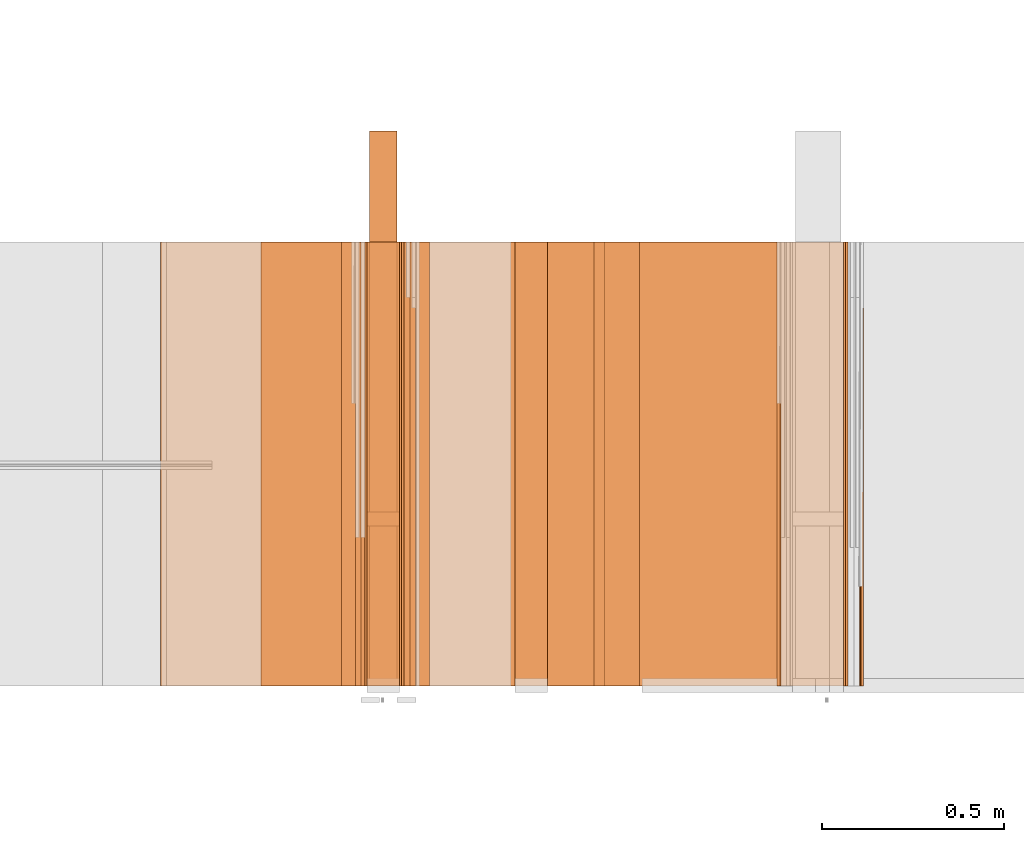
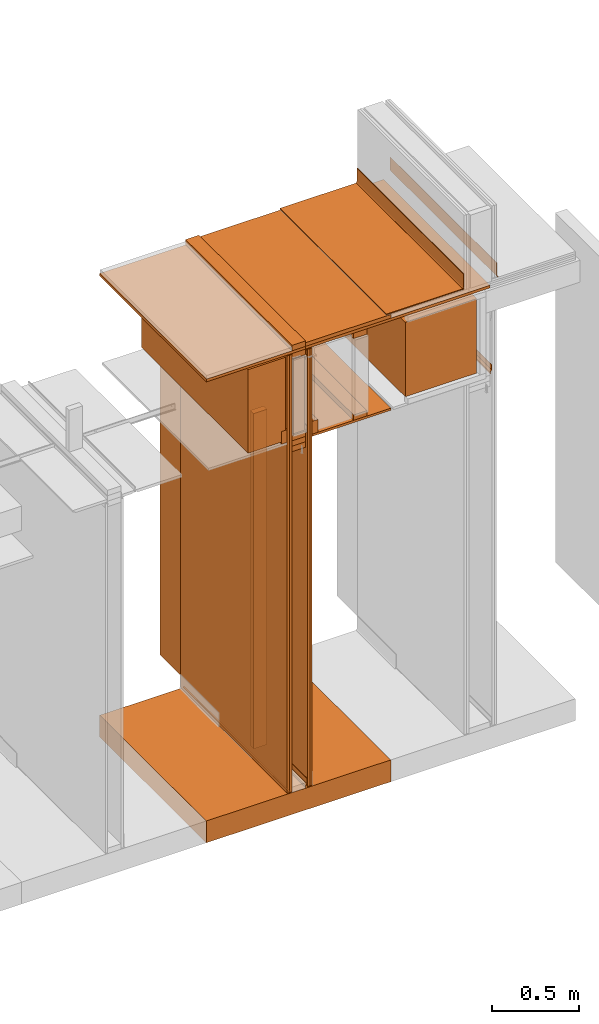
# One storey, part 35 of 64: 31 proxies.
"""IFC4 building model written with IfcOpenShell, lengths in feet."""

from ifc_helpers import new_model, entity, si_unit, converted_unit, frame, origin_with_axes, origin_2d_with_axis, place, context, subcontext, project, spatial, polyline, outline, extrude, material, element, save


model = new_model("IFC4")

# Units and contexts
model_context_1 = context("Model", 3, precision=1e-05, world=origin_with_axes())
plan_context = context("Plan", 2, precision=1e-05, world=origin_2d_with_axis())
model_context_2 = context("Model", 3, precision=1e-05, world=origin_with_axes())
context_of_model_1 = context(None, 3, precision=1e-05, world=origin_with_axes())
context_of_model_2 = context(None, 3, precision=1e-05, world=origin_with_axes())
body_context = subcontext(model_context_2, "Body", "Model", "MODEL_VIEW")
ifc_project = project(units=[converted_unit("PLANEANGLEUNIT", "degree", entity("IfcReal", 0.0174532925199433), si_unit("PLANEANGLEUNIT", "RADIAN"), dimensions=[0, 0, 0, 0, 0, 0, 0]), converted_unit("AREAUNIT", "square foot", entity("IfcReal", 0.09290304), si_unit("AREAUNIT", "SQUARE_METRE"), dimensions=[2, 0, 0, 0, 0, 0, 0]), converted_unit("LENGTHUNIT", "foot", entity("IfcReal", 0.3048), si_unit("LENGTHUNIT", "METRE"), dimensions=[1, 0, 0, 0, 0, 0, 0]), converted_unit("VOLUMEUNIT", "cubic foot", entity("IfcReal", 0.0283168467116885), si_unit("VOLUMEUNIT", "CUBIC_METRE"), dimensions=[3, 0, 0, 0, 0, 0, 0])], contexts=[model_context_1, plan_context, context_of_model_1, context_of_model_2])

# Site, building, storey
site_placement = place(None, origin_with_axes())
site = spatial("IfcSite", under=ifc_project, at=site_placement)
building_placement = place(site_placement, origin_with_axes())
building = spatial("IfcBuilding", under=site, at=building_placement, Name="Building")
storey_placement = place(building_placement, origin_with_axes())
storey = spatial("IfcBuildingStorey", under=building, at=storey_placement, Name="Storey")

# Proxies
proxy_1_placement = place(storey_placement, frame((1385.08854262785, 5.99999987860051, 10.2291668806802), z_axis=(4.37113882867379e-08, -0.999999999999999, -8.51092183247426e-15), x_axis=(1.94707183709394e-07, 0.0, 0.999999999999981)))
element("IfcBuildingElementProxy", 1, at=proxy_1_placement, inside=storey, Name="Generic Models 481:Generic Models 1", PredefinedType="COMPLEX", context=body_context, shape_type="SweptSolid", body=[
    extrude(outline(polyline([(0.841210442265188, 1.5277603110856e-09), (0.840952409690446, 0.0208317411555041), (-0.841210344488539, -1.52776231444079e-09), (-0.840952409690446, -0.0208317411555041), (0.841210442265188, 1.5277603110856e-09)])), frame((0.0104168307749931, -0.841145811900692, -4.91378999315555e-07), z_axis=(0.0, 1.19209303761636e-07, -1.0), x_axis=(0.0123831462115049, -0.999923288822174, -1.19200159076627e-07)), (9.4569436726033e-09, 5.15735579242893e-11, -1.0), 4.00000000752362),
])
ifc_material_1 = material(Name="WALL BASE AS SCHEDULED")
proxy_2_placement = place(storey_placement, frame((1387.47918637093, 5.99999987860051, 10.2500003466769), z_axis=(4.37113882867379e-08, -0.999999999999999, -8.51092183247426e-15), x_axis=(1.94707183709394e-07, 0.0, 0.999999999999981)))
element("IfcBuildingElementProxy", 2, at=proxy_2_placement, inside=storey, material=ifc_material_1, Name="Generic Models 482:Generic Models 1", PredefinedType="COMPLEX", context=body_context, shape_type="SweptSolid", body=[
    extrude(outline(polyline([(0.220647404395689, -6.29889932135151e-10), (0.220442880091705, 0.00356434038693569), (0.218163535311779, 0.00828269806756513), (0.213215401361934, 0.0100073574497083), (-0.0621307594823869, -0.00579188951520919), (-0.0746566692264531, -0.00486853115414599), (-0.0865167811063174, -0.000734690297517212), (-0.0969028489033538, 0.00632791332301642), (-0.105107085793976, 0.0158379745383666), (-0.113815000754955, 0.0101214184931765), (-0.103834498272793, -0.00144763436187376), (-0.0911997814523423, -0.0100393357608477), (-0.0767718836802041, -0.015068177458906), (-0.0615340408201762, -0.0161914508716445), (0.220647404395689, -6.29889932135151e-10)])), frame((0.113048297389755, -0.0126398416918035, -3.92613419174284e-07), z_axis=(2.9828852061986e-13, 1.19209985882662e-07, -1.0), x_axis=(0.998357832431793, 0.0572855435311794, 6.82911327487545e-09)), (1.19549747878978e-09, -3.9874780560778e-11, -1.0), 4.00000000752362),
])
proxy_3_placement = place(storey_placement, frame((1386.73637169865, 5.99999987860051, 10.2500003466769), z_axis=(4.37113882867379e-08, -0.999999999999999, -8.51092183247426e-15), x_axis=(1.94707183709394e-07, 0.0, 0.999999999999981)))
element("IfcBuildingElementProxy", 3, at=proxy_3_placement, inside=storey, material=ifc_material_1, Name="Generic Models 483:Generic Models 1", PredefinedType="COMPLEX", context=body_context, shape_type="SweptSolid", body=[
    extrude(outline(polyline([(0.220471699758777, 4.70219335909461e-14), (0.220618560284454, 0.00356717934719534), (-0.0617877590003132, 0.0151945186382908), (-0.0770054476487198, 0.0138250451530098), (-0.0913501619373563, 0.00856360503083726), (-0.103844324825943, -0.000231237571779394), (-0.113636497261487, -0.0119601335716275), (-0.104837283355201, -0.017535163265631), (-0.0967878757870886, -0.00789370513068918), (-0.0865173433220449, -0.00066411264929456), (-0.0747256200965934, 0.00366092576422873), (-0.0622162712723251, 0.0047866703289759), (0.213349355370041, -0.00655902256294498), (0.218268938538596, -0.00475459118566801), (0.220471699758777, 4.70219335909461e-14)])), frame((0.113048297389755, -0.0218330443105868, -3.93709305460639e-07), z_axis=(2.13063192712774e-14, 1.19209786930696e-07, -1.0), x_axis=(0.9991534948349, -0.0411373302340508, -4.904030070918e-09)), (3.23774618227191e-10, -4.20998902406211e-10, -1.0), 4.00000000752362),
])
proxy_4_placement = place(storey_placement, frame((1385.49674527226, 5.99999987860051, 8.21273314358368), z_axis=(4.37113882867379e-08, -0.999999999999999, -8.51092183247426e-15), x_axis=(1.94707183709394e-07, 0.0, 0.999999999999981)))
element("IfcBuildingElementProxy", 4, at=proxy_4_placement, inside=storey, Name="Generic Models 486:Generic Models 1", PredefinedType="COMPLEX", context=body_context, shape_type="SweptSolid", body=[
    extrude(outline(polyline([(-0.852982848491569, -0.774327352682124), (0.852982946268217, -0.774327352682124), (0.852982946268217, 0.774327352682124), (-0.85298275071492, 0.774327401570448), (-0.852982848491569, -0.774327352682124)])), frame((0.852983044044865, -0.774327206017151, -4.83413600779405e-07), z_axis=(-2.1711843071039e-14, 1.19209289550781e-07, -1.0), x_axis=(-1.0, -1.71943639770689e-07, 0.0)), (8.84101769571544e-09, -3.01153968429446e-09, -1.0), 4.00000000752362),
])
proxy_5_placement = place(storey_placement, frame((1387.33330674059, 5.99999987860051, 8.0949013314535), z_axis=(4.37113882867379e-08, -0.999999999999999, -8.51092183247426e-15), x_axis=(1.94707183709394e-07, 0.0, 0.999999999999981)))
element("IfcBuildingElementProxy", 5, at=proxy_5_placement, inside=storey, Name="Generic Models 487:Generic Models 1", PredefinedType="COMPLEX", context=body_context, shape_type="SweptSolid", body=[
    extrude(outline(polyline([(0.0909011349023327, -1.52771368754651e-09), (0.106510742912142, -0.0224037100793183), (0.110784095768228, -0.0194262812803854), (0.0939412186719145, 0.00474751612851078), (-0.0261054912049157, 0.0262034236847025), (-0.0684096397260043, -0.00327164942784885), (-0.107302623764267, 0.00367967978369181), (-0.1082189865117, -0.00144740758497962), (-0.0672022875623284, -0.00877830727280086), (-0.0248981451522803, 0.0206967635481103), (0.0909011349023327, -1.52771368754651e-09)])), frame((0.106276176732982, -0.0204650267807087, -3.93546216320895e-07), z_axis=(-2.86421862789876e-12, 1.19209985882662e-07, -1.0), x_axis=(0.984400570392609, -0.175941362977028, -2.09736619183332e-08)), (-1.20826360028303e-09, -9.42844552431765e-11, -1.0), 4.00000000752362),
])
ifc_material_2 = material(Name="ACOUSTICAL SEALANT", Category="sealant")
proxy_6_placement = place(storey_placement, frame((1382.98955802217, 5.99999987860051, 0.0), z_axis=(4.37113882867379e-08, -0.999999999999999, -8.51092183247426e-15), x_axis=(1.94707183709394e-07, 0.0, 0.999999999999981)))
element("IfcBuildingElementProxy", 6, at=proxy_6_placement, inside=storey, material=ifc_material_2, Name="Generic Models 246:Generic Models 1", PredefinedType="COMPLEX", context=body_context, shape_type="SweptSolid", body=[
    extrude(outline(polyline([(0.0175297320783725, 1.21719171997307e-09), (-0.00760452534631872, 0.0185696447874344), (-0.0101125697065096, 0.00747135049587707), (-0.0199842895564484, 0.00181347361657025), (0.0051499686321229, -0.0167561721257142), (0.0150216861904215, -0.0110982927637972), (0.0175297320783725, 1.21719171997307e-09)])), frame((0.0104166711240596, -0.0171509025657545, -3.9315117507417e-07), z_axis=(1.14723269946382e-12, 1.19208550586336e-07, -1.0), x_axis=(-0.594228446483612, -0.804296314716339, -9.58762740310704e-08)), (-1.04803887790439e-10, 1.77274347978873e-10, -1.0), 4.00000000752362),
])
proxy_7_placement = place(storey_placement, frame((1383.37503268024, 5.99999987860051, 0.0208333330815585), z_axis=(4.37113882867379e-08, -0.999999999999999, -8.51092183247426e-15), x_axis=(1.94707183709394e-07, 0.0, 0.999999999999981)))
element("IfcBuildingElementProxy", 7, at=proxy_7_placement, inside=storey, Name="Generic Models 25:Generic Models 1", PredefinedType="COMPLEX", context=body_context, shape_type="SweptSolid", body=[
    extrude(outline(polyline([(-5.01041650146324, -0.0260416674977682), (5.01041650146324, -0.0260416674977682), (5.01041650146324, 0.0260416705532884), (-5.01041650146324, 0.0260416674977682), (-5.01041650146324, -0.0260416674977682)])), frame((5.01041650146324, -0.0260406927868059, -3.10445129795532e-09), z_axis=(-3.16621932123194e-14, 1.19209289550781e-07, -1.0), x_axis=(1.0, 1.94707183709397e-07, -8.51092267950722e-15)), (-1.26760935081904e-09, 1.6927841073322e-10, -1.0), 4.00000000752362),
])
ifc_material_3 = material(Name="STRUCTURAL FLOOR", Category="concrete")
proxy_8_placement = place(storey_placement, frame((1381.18233267717, 5.99999987860051, -0.500000006179484), z_axis=(4.37113882867379e-08, -0.999999999999999, -8.51092183247426e-15), x_axis=(1.94707183709394e-07, 0.0, 0.999999999999981)))
element("IfcBuildingElementProxy", 8, at=proxy_8_placement, inside=storey, material=ifc_material_3, Name="Generic Models 28:Generic Models 1", PredefinedType="COMPLEX", context=body_context, shape_type="SweptSolid", body=[
    extrude(outline(polyline([(-0.250000003089742, -2.00000002471794), (0.250000003089742, -2.00000002471794), (0.250000003089742, 2.00000002471794), (-0.250000003089742, 2.00000002471794), (-0.250000003089742, -2.00000002471794)])), frame((0.250000394196335, -2.00000002471794, -2.3841858204817e-07), z_axis=(0.0, 1.19209289550781e-07, -1.0), x_axis=(1.0, 1.94707183709397e-07, -8.51092267950722e-15)), (4.23030166452065e-10, -9.26341314766432e-09, -1.0), 4.00000000752362),
])
proxy_9_placement = place(storey_placement, frame((1383.33338139251, 5.99999987860051, 0.0115680431010901), z_axis=(4.37113882867379e-08, -0.999999999999999, -8.51092183247426e-15), x_axis=(1.94707183709394e-07, 0.0, 0.999999999999981)))
element("IfcBuildingElementProxy", 9, at=proxy_9_placement, inside=storey, Name="Generic Models 29:Generic Models 1", PredefinedType="COMPLEX", context=body_context, shape_type="SweptSolid", body=[
    extrude(outline(polyline([(0.0667668759255741, 0.0152567137531408), (0.106276176732982, 0.0152567137531408), (0.106276176732982, 0.0204650481693505), (0.0646095075143447, 0.0204650481693505), (0.0281511742396774, -0.0159932851053168), (-0.089483129061035, -0.0159932866330769), (-0.108790967681902, 0.00331456230017124), (-0.112473822915022, -0.000368285962543022), (-0.0916404974722643, -0.0212016195215265), (0.0303085395953865, -0.0212016210492867), (0.0667668759255741, 0.0152567137531408)])), frame((0.106276176732982, -0.0204650283084689, -3.93546216320895e-07), z_axis=(-2.48385014813002e-12, 1.19210000093517e-07, -1.0), x_axis=(-1.0, -1.93341818999215e-07, 0.0)), (9.89209492097132e-10, -1.26986490767145e-10, -1.0), 4.00000000752362),
])
proxy_10_placement = place(storey_placement, frame((1383.04162213183, 5.99999987860051, 7.81249968711472), z_axis=(4.37113882867379e-08, -0.999999999999999, -8.51092183247426e-15), x_axis=(1.94707183709394e-07, 0.0, 0.999999999999981)))
element("IfcBuildingElementProxy", 10, at=proxy_10_placement, inside=storey, Name="Generic Models 359:Generic Models 1", PredefinedType="COMPLEX", context=body_context, shape_type="SweptSolid", body=[
    extrude(outline(polyline([(-0.145833333098669, -0.0625000007724355), (0.145833333098669, -0.0625000007724355), (0.145833333098669, 0.0625000007724355), (-0.145833333098669, 0.062500006883476), (-0.145833333098669, -0.0625000007724355)])), frame((0.0625000313276381, -0.145833320876588, -4.08491298529716e-07), z_axis=(-1.6389038902582e-14, 1.19209246918217e-07, -1.0), x_axis=(-1.94707197920252e-07, 1.0, 1.19209254023644e-07)), (5.71730267295845e-11, 5.40085143274638e-10, -1.0), 4.00000000752362),
])
proxy_11_placement = place(storey_placement, frame((1382.08594534967, 5.99999987860051, 8.1138363660477), z_axis=(4.37113882867379e-08, -0.999999999999999, -8.51092183247426e-15), x_axis=(1.94707183709394e-07, 0.0, 0.999999999999981)))
element("IfcBuildingElementProxy", 11, at=proxy_11_placement, inside=storey, Name="Generic Models 35:Generic Models 1", PredefinedType="COMPLEX", context=body_context, shape_type="SweptSolid", body=[
    extrude(outline(polyline([(-0.717593576964431, -0.513735034177935), (1.19485684580064, -0.513735034177935), (1.19485684580064, 0.300924672581392), (-0.477263122171242, 0.300924697025554), (-0.477263073282918, 0.212810239375733), (-0.717593576964431, 0.212810239375733), (-0.717593576964431, -0.513735034177935)])), frame((0.717593674741079, -0.513734887512963, -4.52348569800187e-07), z_axis=(-8.97603016491045e-15, 1.19209332183345e-07, -1.0), x_axis=(1.0, 1.94707197920252e-07, 0.0)), (-5.62830615447041e-10, 1.27540444871954e-09, -1.0), 4.00000000752362),
])
proxy_12_placement = place(storey_placement, frame((1383.06254789898, 6.99999998873613, 0.125000001544871), z_axis=(4.37113882867379e-08, -0.999999999999999, -8.51092183247426e-15), x_axis=(1.94707183709394e-07, 0.0, 0.999999999999981)))
element("IfcBuildingElementProxy", 12, at=proxy_12_placement, inside=storey, Name="Generic Models 361:Generic Models 1", PredefinedType="COMPLEX", context=body_context, shape_type="SweptSolid", body=[
    extrude(outline(polyline([(-0.125000001544871, -3.83239327453253), (0.125000001544871, -3.83239327453253), (0.125000001544871, 3.83239327453253), (-0.125000001544871, 3.83239327453253), (-0.125000001544871, -3.83239327453253)])), frame((3.83239327453253, -0.124999255997928, -1.49011934316938e-08), z_axis=(-3.14942774008557e-14, 1.19209289550781e-07, -1.0), x_axis=(-1.94707183709397e-07, 1.0, 1.19209289550781e-07)), (-1.17887616335466e-10, -6.08459460593735e-09, -1.0), 4.00000000752362),
])
proxy_13_placement = place(storey_placement, frame((1383.04162213183, 5.99999987860051, 8.06249971464863), z_axis=(4.37113882867379e-08, -0.999999999999999, -8.51092183247426e-15), x_axis=(1.94707183709394e-07, 0.0, 0.999999999999981)))
element("IfcBuildingElementProxy", 13, at=proxy_13_placement, inside=storey, Name="Generic Models 362:Generic Models 1", PredefinedType="COMPLEX", context=body_context, shape_type="SweptSolid", body=[
    extrude(outline(polyline([(-0.062500006883476, -0.145833320876588), (0.0625000007724355, -0.145833320876588), (0.0625000007724355, 0.14583334532075), (-0.0625000007724355, 0.14583334532075), (-0.062500006883476, -0.145833320876588)])), frame((0.0625000313276381, -0.145833333098669, -4.08491298529716e-07), z_axis=(-1.6389038902582e-14, 1.19209246918217e-07, -1.0), x_axis=(-1.0, -1.9555329799914e-07, 0.0)), (-5.09230324574617e-10, 4.39412291275421e-11, -1.0), 4.00000000752362),
])
proxy_14_placement = place(storey_placement, frame((1383.04162213183, 5.99999987860051, 7.93749970088168), z_axis=(4.37113882867379e-08, -0.999999999999999, -8.51092183247426e-15), x_axis=(1.94707183709394e-07, 0.0, 0.999999999999981)))
element("IfcBuildingElementProxy", 14, at=proxy_14_placement, inside=storey, Name="Generic Models 364:Generic Models 1", PredefinedType="COMPLEX", context=body_context, shape_type="SweptSolid", body=[
    extrude(outline(polyline([(-0.145833333098669, -0.0625000007724355), (0.145833333098669, -0.0625000007724355), (0.145833333098669, 0.0625000007724355), (-0.145833333098669, 0.062500006883476), (-0.145833333098669, -0.0625000007724355)])), frame((0.0625000313276381, -0.145833320876588, -4.08491298529716e-07), z_axis=(-1.6389038902582e-14, 1.19209246918217e-07, -1.0), x_axis=(-1.94707197920252e-07, 1.0, 1.19209254023644e-07)), (5.71730267295845e-11, 5.40085143274638e-10, -1.0), 4.00000000752362),
])
proxy_15_placement = place(storey_placement, frame((1382.98955802217, 5.99999987860051, 0.0208333330815585), z_axis=(4.37113882867379e-08, -0.999999999999999, -8.51092183247426e-15), x_axis=(1.94707183709394e-07, 0.0, 0.999999999999981)))
element("IfcBuildingElementProxy", 15, at=proxy_15_placement, inside=storey, Name="Generic Models 368:Generic Models 1", PredefinedType="COMPLEX", context=body_context, shape_type="SweptSolid", body=[
    extrude(outline(polyline([(-5.01041650146324, -0.0260416705532884), (5.01041650146324, -0.0260416705532884), (5.01041650146324, 0.0260416644422479), (-5.01041650146324, 0.0260416674977682), (-5.01041650146324, -0.0260416705532884)])), frame((5.01041650146324, -0.0260406897312856, -3.94211067988345e-07), z_axis=(-3.24850552273909e-14, 1.19209161653089e-07, -1.0), x_axis=(-1.0, -1.945369092482e-07, 9.30532184645208e-15)), (1.26650134824047e-09, 4.38610953112928e-11, -1.0), 4.00000000752362),
])
ifc_material_4 = material(Category="sand")
proxy_16_placement = place(storey_placement, frame((1382.9374939125, 5.99999987860051, 0.0208333330815585), z_axis=(4.37113882867379e-08, -0.999999999999999, -8.51092183247426e-15), x_axis=(1.94707183709394e-07, 0.0, 0.999999999999981)))
element("IfcBuildingElementProxy", 16, at=proxy_16_placement, inside=storey, material=ifc_material_4, Name="Generic Models 370:Generic Models 1", PredefinedType="COMPLEX", context=body_context, shape_type="SweptSolid", body=[
    extrude(outline(polyline([(-5.01041650146324, -0.0260416674977682), (5.01041650146324, -0.0260416674977682), (5.01041650146324, 0.0260416705532884), (-5.01041650146324, 0.0260416674977682), (-5.01041650146324, -0.0260416674977682)])), frame((5.01041650146324, -0.0260406927868059, -3.94211021364806e-07), z_axis=(-3.24850552273909e-14, 1.19209161653089e-07, -1.0), x_axis=(1.0, 1.94707183709397e-07, -9.30532184645208e-15)), (-1.26761012797516e-09, 1.69418284956535e-10, -1.0), 4.00000000752362),
])
proxy_17_placement = place(storey_placement, frame((1383.4270967899, 5.99999987860051, 0.0208333330815585), z_axis=(4.37113882867379e-08, -0.999999999999999, -8.51092183247426e-15), x_axis=(1.94707183709394e-07, 0.0, 0.999999999999981)))
element("IfcBuildingElementProxy", 17, at=proxy_17_placement, inside=storey, material=ifc_material_4, Name="Generic Models 371:Generic Models 1", PredefinedType="COMPLEX", context=body_context, shape_type="SweptSolid", body=[
    extrude(outline(polyline([(-5.01041650146324, -0.0260416674977682), (5.01041650146324, -0.0260416674977682), (5.01041650146324, 0.0260416705532884), (-5.01041650146324, 0.0260416674977682), (-5.01041650146324, -0.0260416674977682)])), frame((5.01041650146324, -0.0260406927868059, -3.10445129795532e-09), z_axis=(-3.16621932123194e-14, 1.19209289550781e-07, -1.0), x_axis=(1.0, 1.94707183709397e-07, -8.51092267950722e-15)), (-1.26760935081904e-09, 1.6927841073322e-10, -1.0), 4.00000000752362),
])
proxy_18_placement = place(storey_placement, frame((1383.04162213183, 5.99999987860051, 9.93749992115291), z_axis=(4.37113882867379e-08, -0.999999999999999, -8.51092183247426e-15), x_axis=(1.94707183709394e-07, 0.0, 0.999999999999981)))
element("IfcBuildingElementProxy", 18, at=proxy_18_placement, inside=storey, Name="Generic Models 379:Generic Models 1", PredefinedType="COMPLEX", context=body_context, shape_type="SweptSolid", body=[
    extrude(outline(polyline([(-0.145833333098669, -0.0625000007724355), (0.145833333098669, -0.0625000007724355), (0.145833333098669, 0.0625000007724355), (-0.145833333098669, 0.062500006883476), (-0.145833333098669, -0.0625000007724355)])), frame((0.0625000313276381, -0.145833320876588, -4.08491298529716e-07), z_axis=(-1.6389038902582e-14, 1.19209246918217e-07, -1.0), x_axis=(-1.94707197920252e-07, 1.0, 1.19209254023644e-07)), (5.71730267295845e-11, 5.40085143274638e-10, -1.0), 4.00000000752362),
])
proxy_19_placement = place(storey_placement, frame((1383.04162213183, 7.44270840341963, 0.125000001544871), z_axis=(0.0, -0.999999999999999, -4.37113882867379e-08), x_axis=(1.0, 0.0, 0.0)))
element("IfcBuildingElementProxy", 19, at=proxy_19_placement, inside=storey, Name="Generic Models 380:Generic Models 1", PredefinedType="COMPLEX", context=body_context, shape_type="SweptSolid", body=[
    extrude(outline(polyline([(-0.145833333098669, -3.84244745171915), (0.145833333098669, -3.84244745171915), (0.145833333098669, 3.84244784282574), (-0.145833333098669, 3.84244784282574), (-0.145833333098669, -3.84244745171915)])), frame((0.145833333098669, 3.84244784282574, 3.87499964456233), z_axis=(0.0, -5.08929005604841e-08, -1.0), x_axis=(-1.0, 0.0, 0.0)), (0.0, 1.50028222378751e-06, -1.0), 0.124999819791014),
])
proxy_20_placement = place(storey_placement, frame((1383.04162213183, 5.99999987860051, 10.1250003329099), z_axis=(4.37113882867379e-08, -0.999999999999999, -8.51092183247426e-15), x_axis=(1.94707183709394e-07, 0.0, 0.999999999999981)))
element("IfcBuildingElementProxy", 20, at=proxy_20_placement, inside=storey, Name="Generic Models 381:Generic Models 1", PredefinedType="COMPLEX", context=body_context, shape_type="SweptSolid", body=[
    extrude(outline(polyline([(-0.145833333098669, -0.0625000007724355), (0.145833333098669, -0.0625000007724355), (0.145833333098669, 0.0625000007724355), (-0.145833333098669, 0.062500006883476), (-0.145833333098669, -0.0625000007724355)])), frame((0.0625000313276381, -0.145833320876588, -4.08491298529716e-07), z_axis=(-1.6389038902582e-14, 1.19209246918217e-07, -1.0), x_axis=(-1.94707197920252e-07, 1.0, 1.19209254023644e-07)), (5.71730267295845e-11, 5.40085143274638e-10, -1.0), 4.00000000752362),
])
proxy_21_placement = place(storey_placement, frame((1381.18233267717, 5.99999987860051, 10.0624999349199), z_axis=(4.37113882867379e-08, -0.999999999999999, -8.51092183247426e-15), x_axis=(1.94707183709394e-07, 0.0, 0.999999999999981)))
element("IfcBuildingElementProxy", 21, at=proxy_21_placement, inside=storey, Name="Generic Models 382:Generic Models 1", PredefinedType="COMPLEX", context=body_context, shape_type="SweptSolid", body=[
    extrude(outline(polyline([(-0.0312503884372905, -2.00000002471794), (0.0312496092796247, -2.00000002471794), (0.0312503884372905, 2.00000002471794), (-0.031249612335145, 2.00000002471794), (-0.0312503884372905, -2.00000002471794)])), frame((0.0312503884372905, -2.00000002471794, -2.3841858204817e-07), z_axis=(0.0, 1.19209289550781e-07, -1.0), x_axis=(-1.0, 0.0, 0.0)), (0.0, 2.14326316694269e-08, -1.0), 4.00000000752362),
])
proxy_22_placement = place(storey_placement, frame((1383.33338139251, 5.99999987860051, 10.1250003329099), z_axis=(4.37113882867379e-08, -0.999999999999999, -8.51092183247426e-15), x_axis=(1.94707183709394e-07, 0.0, 0.999999999999981)))
element("IfcBuildingElementProxy", 22, at=proxy_22_placement, inside=storey, Name="Generic Models 383:Generic Models 1", PredefinedType="COMPLEX", context=body_context, shape_type="SweptSolid", body=[
    extrude(outline(polyline([(-0.0416668494943324, -0.92447918700421), (0.041666488942942, -0.92447918700421), (0.0416668494943324, 0.92447918700421), (-0.041666488942942, 0.92447918700421), (-0.0416668494943324, -0.92447918700421)])), frame((0.0416668494943324, -0.92447918700421, -5.0131307678986e-07), z_axis=(0.0, 1.19209289550781e-07, -1.0), x_axis=(-1.0, 0.0, 0.0)), (0.0, -3.01153102455487e-09, -1.0), 4.00000000752362),
])
proxy_23_placement = place(storey_placement, frame((1383.47916089957, 5.99999987860051, 8.01041683187009), z_axis=(4.37113882867379e-08, -0.999999999999999, -8.51092183247426e-15), x_axis=(1.94707183709394e-07, 0.0, 0.999999999999981)))
element("IfcBuildingElementProxy", 23, at=proxy_23_placement, inside=storey, Name="Generic Models 434:Generic Models 1", PredefinedType="COMPLEX", context=body_context, shape_type="SweptSolid", body=[
    extrude(outline(polyline([(-0.0260418324958621, -0.851562544899037), (0.026041499444154, -0.851562544899037), (0.0260418324958621, 0.851562544899037), (-0.0260415024996742, 0.851562544899037), (-0.0260418324958621, -0.851562544899037)])), frame((0.0260418324958621, -0.851562544899037, -1.01514165985469e-07), z_axis=(0.0, 1.19209289550781e-07, -1.0), x_axis=(-1.0, 0.0, 0.0)), (0.0, -3.01151925619081e-09, -1.0), 4.00000000752362),
])
proxy_24_placement = place(storey_placement, frame((1384.37496395562, 5.99999987860051, 8.06249971464863), z_axis=(4.37113882867379e-08, -0.999999999999999, -8.51092183247426e-15), x_axis=(1.94707183709394e-07, 0.0, 0.999999999999981)))
element("IfcBuildingElementProxy", 24, at=proxy_24_placement, inside=storey, Name="Generic Models 436:Generic Models 1", PredefinedType="COMPLEX", context=body_context, shape_type="SweptSolid", body=[
    extrude(outline(polyline([(-0.062500006883476, -0.145833320876588), (0.0625000007724355, -0.145833320876588), (0.0625000007724355, 0.14583334532075), (-0.0625000007724355, 0.14583334532075), (-0.062500006883476, -0.145833320876588)])), frame((0.0625000313276381, -0.145833333098669, -4.08491298529716e-07), z_axis=(-1.6389038902582e-14, 1.19209246918217e-07, -1.0), x_axis=(-1.0, -1.9555329799914e-07, 0.0)), (-5.09230324574617e-10, 4.39412291275421e-11, -1.0), 4.00000000752362),
])
proxy_25_placement = place(storey_placement, frame((1383.47916089957, 5.99999987860051, 8.06249971464863), z_axis=(4.37113882867379e-08, -0.999999999999999, -8.51092183247426e-15), x_axis=(1.94707183709394e-07, 0.0, 0.999999999999981)))
element("IfcBuildingElementProxy", 25, at=proxy_25_placement, inside=storey, Name="Generic Models 438:Generic Models 1", PredefinedType="COMPLEX", context=body_context, shape_type="SweptSolid", body=[
    extrude(outline(polyline([(-0.145833333098669, -0.0625000007724355), (0.145833333098669, -0.0625000007724355), (0.145833333098669, 0.0625000007724355), (-0.145833333098669, 0.062499994661395), (-0.145833333098669, -0.0625000007724355)])), frame((0.14583334532075, -0.0624999702172329, -7.45058214599091e-09), z_axis=(-3.48267083032615e-14, 1.19209289550781e-07, -1.0), x_axis=(-1.0, -2.09521402894097e-07, 9.99075869506216e-15)), (2.1828501506338e-10, 4.3999508897441e-11, -1.0), 4.00000000752362),
])
proxy_26_placement = place(storey_placement, frame((1382.81254004931, 5.99999987860051, 8.06249971464863), z_axis=(4.37113882867379e-08, -0.999999999999999, -8.51092183247426e-15), x_axis=(1.94707183709394e-07, 0.0, 0.999999999999981)))
element("IfcBuildingElementProxy", 26, at=proxy_26_placement, inside=storey, Name="Generic Models 439:Generic Models 1", PredefinedType="COMPLEX", context=body_context, shape_type="SweptSolid", body=[
    extrude(outline(polyline([(-0.0625000007724355, -0.145833333098669), (0.0625000007724355, -0.145833333098669), (0.0625000007724355, 0.145833333098669), (-0.062499994661395, 0.145833333098669), (-0.0625000007724355, -0.145833333098669)])), frame((0.14583334532075, -0.0624999702172329, -3.98557174431872e-07), z_axis=(-2.66321880049375e-14, 1.19209289550781e-07, -1.0), x_axis=(-1.94707183709397e-07, 1.0, 1.19209303761636e-07)), (5.84101877976195e-10, 1.31954117771338e-11, -1.0), 4.00000000752362),
])
proxy_27_placement = place(storey_placement, frame((1384.37496395562, 5.99999987860051, 9.93749992115291), z_axis=(4.37113882867379e-08, -0.999999999999999, -8.51092183247426e-15), x_axis=(1.94707183709394e-07, 0.0, 0.999999999999981)))
element("IfcBuildingElementProxy", 27, at=proxy_27_placement, inside=storey, Name="Generic Models 440:Generic Models 1", PredefinedType="COMPLEX", context=body_context, shape_type="SweptSolid", body=[
    extrude(outline(polyline([(-0.145833333098669, -0.0625000007724355), (0.145833333098669, -0.0625000007724355), (0.145833333098669, 0.0625000007724355), (-0.145833333098669, 0.062500006883476), (-0.145833333098669, -0.0625000007724355)])), frame((0.0625000313276381, -0.145833320876588, -4.08491298529716e-07), z_axis=(-1.6389038902582e-14, 1.19209246918217e-07, -1.0), x_axis=(-1.94707197920252e-07, 1.0, 1.19209254023644e-07)), (5.71730267295845e-11, 5.40085143274638e-10, -1.0), 4.00000000752362),
])
proxy_28_placement = place(storey_placement, frame((1383.33338139251, 5.99999987860051, 9.82406805819414), z_axis=(4.37113882867379e-08, -0.999999999999999, -8.51092183247426e-15), x_axis=(1.94707183709394e-07, 0.0, 0.999999999999981)))
element("IfcBuildingElementProxy", 28, at=proxy_28_placement, inside=storey, Name="Generic Models 441:Generic Models 1", PredefinedType="COMPLEX", context=body_context, shape_type="SweptSolid", body=[
    extrude(outline(polyline([(0.0909011349023327, -1.52771368754651e-09), (0.106510742912142, -0.0224037100793183), (0.110784095768228, -0.0194262812803854), (0.0939412186719145, 0.00474751612851078), (-0.0261054912049157, 0.0262034236847025), (-0.0684096397260043, -0.00327164942784885), (-0.107302623764267, 0.00367967978369181), (-0.1082189865117, -0.00144740758497962), (-0.0672022875623284, -0.00877830727280086), (-0.0248981451522803, 0.0206967635481103), (0.0909011349023327, -1.52771368754651e-09)])), frame((0.106276176732982, -0.0204650267807087, -3.93546216320895e-07), z_axis=(-2.86421862789876e-12, 1.19209985882662e-07, -1.0), x_axis=(0.984400570392609, -0.175941362977028, -2.09736619183332e-08)), (-1.20826360028303e-09, -9.42844552431765e-11, -1.0), 4.00000000752362),
])
ifc_material_5 = material(Category="InsulationBatt")
proxy_29_placement = place(storey_placement, frame((1383.06254789898, 5.99999987860051, 8.21273314358368), z_axis=(4.37113882867379e-08, -0.999999999999999, -8.51092183247426e-15), x_axis=(1.94707183709394e-07, 0.0, 0.999999999999981)))
element("IfcBuildingElementProxy", 29, at=proxy_29_placement, inside=storey, material=ifc_material_5, Name="Generic Models 442:Generic Models 1", PredefinedType="COMPLEX", context=body_context, shape_type="SweptSolid", body=[
    extrude(outline(polyline([(-0.125000001544871, -0.852982848491569), (0.125000001544871, -0.852982848491569), (0.125000001544871, 0.852982848491569), (-0.12499998932279, 0.852982848491569), (-0.125000001544871, -0.852982848491569)])), frame((0.852982848491569, -0.124999830435737, -4.0600775584937e-07), z_axis=(-2.45176041334351e-14, 1.19209303761636e-07, -1.0), x_axis=(-1.94707183709397e-07, 1.0, 1.19209303761636e-07)), (-1.75470893370999e-09, -6.08461681039785e-09, -1.0), 4.00000000752362),
])
proxy_30_placement = place(storey_placement, frame((1383.33338139251, 5.99999987860051, 8.0949013314535), z_axis=(4.37113882867379e-08, -0.999999999999999, -8.51092183247426e-15), x_axis=(1.94707183709394e-07, 0.0, 0.999999999999981)))
element("IfcBuildingElementProxy", 30, at=proxy_30_placement, inside=storey, Name="Generic Models 443:Generic Models 1", PredefinedType="COMPLEX", context=body_context, shape_type="SweptSolid", body=[
    extrude(outline(polyline([(0.0909011349023327, -1.52771368754651e-09), (0.106510742912142, -0.0224037100793183), (0.110784095768228, -0.0194262812803854), (0.0939412186719145, 0.00474751612851078), (-0.0261054912049157, 0.0262034236847025), (-0.0684096397260043, -0.00327164942784885), (-0.107302623764267, 0.00367967978369181), (-0.1082189865117, -0.00144740758497962), (-0.0672022875623284, -0.00877830727280086), (-0.0248981451522803, 0.0206967635481103), (0.0909011349023327, -1.52771368754651e-09)])), frame((0.106276176732982, -0.0204650267807087, -3.93546216320895e-07), z_axis=(-2.86421862789876e-12, 1.19209985882662e-07, -1.0), x_axis=(0.984400570392609, -0.175941362977028, -2.09736619183332e-08)), (-1.20826360028303e-09, -9.42844552431765e-11, -1.0), 4.00000000752362),
])
proxy_31_placement = place(storey_placement, frame((1383.33338139251, 5.99999987860051, 10.0624999349199), z_axis=(4.37113882867379e-08, -0.999999999999999, -8.51092183247426e-15), x_axis=(1.94707183709394e-07, 0.0, 0.999999999999981)))
element("IfcBuildingElementProxy", 31, at=proxy_31_placement, inside=storey, Name="Generic Models 448:Generic Models 1", PredefinedType="COMPLEX", context=body_context, shape_type="SweptSolid", body=[
    extrude(outline(polyline([(-0.0312500003862178, -2.00000002471794), (0.0312500003862178, -2.00000002471794), (0.0312499973306975, 2.00000002471794), (-0.0312500003862178, 2.00000002471794), (-0.0312500003862178, -2.00000002471794)])), frame((0.0312503884372905, -2.00000002471794, -6.29525198374314e-07), z_axis=(0.0, 1.19209303761636e-07, -1.0), x_axis=(1.0, 1.94707183709397e-07, 0.0)), (-3.40841382895363e-10, -1.99114627008612e-08, -1.0), 4.00000000752362),
])

save(model, "model.ifc")
